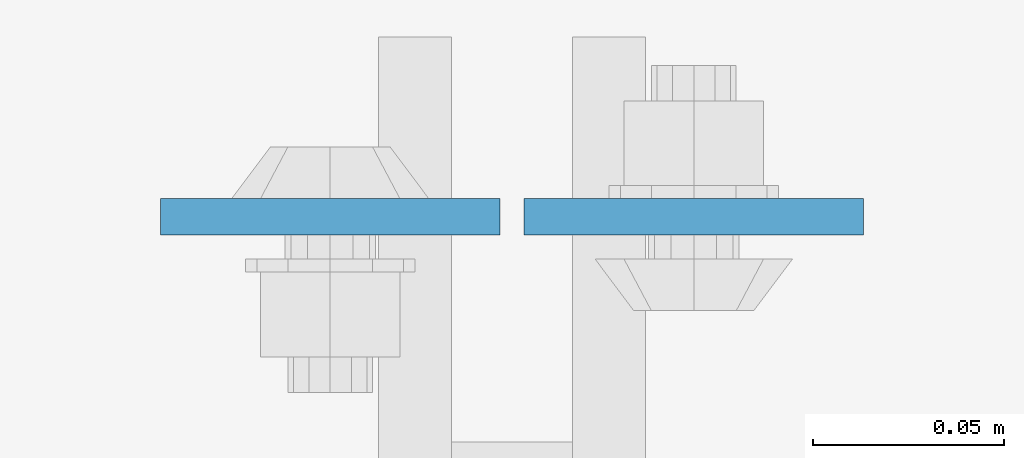
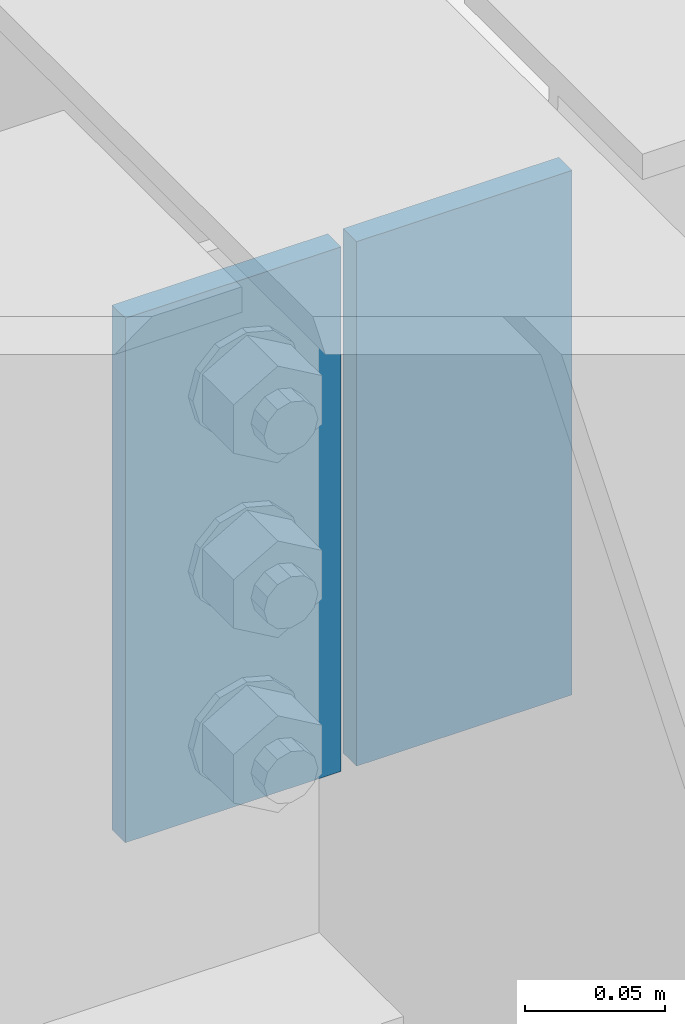
# One storey, part 3124 of 3843: 2 plates, 1 element without a shape of its own.
"""IFC2X3 building model written with IfcOpenShell, lengths in millimetres."""

import ifcopenshell
import ifcopenshell.guid

model = None  # the IFC model being written
_history = None  # IfcOwnerHistory: only IFC2X3 demands one
_inside = {}  # id of a spatial element -> (the spatial element, [elements in it])
_under = {}  # id of a project, library or spatial element -> (it, [spatial elements below it])
_declared = {}  # id of a project -> (the project, [libraries it declares])
_typed = {}  # id of a type object -> (the type object, [elements of that type])
_made_of = {}  # id of a material, layer set ... -> (it, [elements and type objects made of it])


def new_model(schema):
    """Start an empty IFC model of exactly this schema.

    Asked for "IFC4X3", IfcOpenShell would pick the latest addendum, in which some entities
    have other attributes; the version numbers below select the first issue.
    IFC2X3 requires an IfcOwnerHistory on every rooted entity: one is made here for all.
    """
    global model, _history
    if schema == "IFC4X3":
        model = ifcopenshell.file(schema_version=(4, 3, 0, 0))
    else:
        model = ifcopenshell.file(schema=schema)
    _inside.clear()
    _under.clear()
    _declared.clear()
    _typed.clear()
    _made_of.clear()
    _history = None
    if model.schema == "IFC2X3":
        org = make("IfcOrganization", Name="unknown")
        user = make(
            "IfcPersonAndOrganization",
            ThePerson=make("IfcPerson", FamilyName="unknown"),
            TheOrganization=org,
        )
        app = make(
            "IfcApplication",
            ApplicationDeveloper=org,
            Version="unknown",
            ApplicationFullName="unknown",
            ApplicationIdentifier="unknown",
        )
        _history = make(
            "IfcOwnerHistory",
            OwningUser=user,
            OwningApplication=app,
            ChangeAction="ADDED",
            CreationDate=0,
        )
    return model


def make(cls, **values):
    """One entity of the class cls with the attributes given. An attribute that is None is left unset."""
    return model.create_entity(
        cls, **{name: value for name, value in values.items() if value is not None}
    )


def rooted(cls, **values):
    """An entity with a GlobalId (a new one), such as an element, a storey or a relation."""
    return make(cls, GlobalId=ifcopenshell.guid.new(), OwnerHistory=_history, **values)


def si_unit(unit_type, name, prefix=None):
    """IfcSIUnit, for example si_unit("LENGTHUNIT", "METRE", prefix="MILLI")."""
    return make("IfcSIUnit", UnitType=unit_type, Prefix=prefix, Name=name)


def assignment(units):
    """IfcUnitAssignment: the units of a project."""
    return None if units is None else make("IfcUnitAssignment", Units=units)


def point(xyz):
    """IfcCartesianPoint."""
    return None if xyz is None else make("IfcCartesianPoint", Coordinates=xyz)


def direction(xyz):
    """IfcDirection."""
    return None if xyz is None else make("IfcDirection", DirectionRatios=xyz)


def frame(location, z_axis=None, x_axis=None):
    """IfcAxis2Placement3D, a coordinate frame: its origin and axes. An axis left out is left unset."""
    return make(
        "IfcAxis2Placement3D",
        Location=point(location),
        Axis=direction(z_axis),
        RefDirection=direction(x_axis),
    )


def origin_with_axes():
    """The frame at (0, 0, 0) with the z axis (0, 0, 1) and the x axis (1, 0, 0) written out."""
    return frame((0.0, 0.0, 0.0), z_axis=(0.0, 0.0, 1.0), x_axis=(1.0, 0.0, 0.0))


def place(relative_to, where):
    """IfcLocalPlacement: puts the frame where relative to a parent placement (None: the world)."""
    return make(
        "IfcLocalPlacement", PlacementRelTo=relative_to, RelativePlacement=where
    )


def context(
    kind, dimensions, precision=None, world=None, true_north=None, identifier=None
):
    """IfcGeometricRepresentationContext, for example the 3D "Model" context."""
    return make(
        "IfcGeometricRepresentationContext",
        ContextIdentifier=identifier,
        ContextType=kind,
        CoordinateSpaceDimension=dimensions,
        Precision=precision,
        WorldCoordinateSystem=world,
        TrueNorth=true_north,
    )


def subcontext(parent, identifier, kind, view, scale=None):
    """IfcGeometricRepresentationSubContext, for example "Body" below "Model"."""
    return make(
        "IfcGeometricRepresentationSubContext",
        ContextIdentifier=identifier,
        ContextType=kind,
        ParentContext=parent,
        TargetScale=scale,
        TargetView=view,
    )


def project(units=None, contexts=None):
    """IfcProject with its units and contexts."""
    return rooted(
        "IfcProject",
        Name="project",
        RepresentationContexts=contexts,
        UnitsInContext=assignment(units),
    )


def spatial(cls, under=None, at=None, **own):
    """A site, building, storey or space (cls), placed at a placement, below another one or the project."""
    s = rooted(cls, ObjectPlacement=at, **own)
    if under is not None:
        _under.setdefault(under.id(), (under, []))[1].append(s)
    return s


def faces_of(points, faces, orient=None, outer=None):
    """IfcFace entities. A face is a list of loops; a loop is a list of indices into points, from 0.

    orient and outer hold one flag for each loop. By default every Orientation is true, the
    first loop of a face is its IfcFaceOuterBound and the others are IfcFaceBound.
    """
    made = []
    for i, loops in enumerate(faces):
        bounds = []
        for j, loop in enumerate(loops):
            is_outer = j == 0 if outer is None else outer[i][j]
            bounds.append(
                make(
                    "IfcFaceOuterBound" if is_outer else "IfcFaceBound",
                    Bound=make("IfcPolyLoop", Polygon=[points[k] for k in loop]),
                    Orientation=True if orient is None else orient[i][j],
                )
            )
        made.append(make("IfcFace", Bounds=bounds))
    return made


def faceted_brep(points, faces, orient=None, outer=None, voids=None):
    """IfcFacetedBrep: a solid bounded by flat faces; with voids (closed shells), ...WithVoids."""
    shared = [point(p) for p in points]
    hull = make("IfcClosedShell", CfsFaces=faces_of(shared, faces, orient, outer))
    if voids is None:
        return make("IfcFacetedBrep", Outer=hull)
    return make(
        "IfcFacetedBrepWithVoids",
        Outer=hull,
        Voids=[
            make(cls, CfsFaces=faces_of(shared, fs, o, b)) for cls, fs, o, b in voids
        ],
    )


def shape(context_of_items, identifier, shape_type, items):
    """IfcShapeRepresentation: the items that make up one representation, for example the "Body"."""
    return make(
        "IfcShapeRepresentation",
        ContextOfItems=context_of_items,
        RepresentationIdentifier=identifier,
        RepresentationType=shape_type,
        Items=items,
    )


def material(Name=None, Category=None):
    """IfcMaterial."""
    return make("IfcMaterial", Name=Name, Category=Category)


def made_of(thing, what):
    """Note that an element or type object is made of a material, layer set ...; save() writes the relation."""
    if what is not None:
        _made_of.setdefault(what.id(), (what, []))[1].append(thing)
    return thing


def type_object(cls, material=None, **own):
    """A type object (cls), such as IfcWallType, which elements share."""
    return made_of(rooted(cls, **own), material)


def element(
    cls,
    number,
    at=None,
    inside=None,
    cuts=None,
    type_object=None,
    material=None,
    context=None,
    identifier="Body",
    shape_type=None,
    held_by="IfcProductDefinitionShape",
    body=None,
    shapes=None,
    **own,
):
    """One element of the class cls, such as IfcWall. Its Tag is "e" and its number.

    at: its placement. inside: the storey or other place that contains it. cuts: it is an
    opening in that element (IfcRelVoidsElement). A single representation is given by context,
    identifier, shape_type and body (its items); several are given by shapes. held_by: the class
    of the entity that holds the representations. save() writes the other relations.
    """
    e = rooted(cls, Tag="e%d" % number, ObjectPlacement=at, **own)
    if body is not None:
        shapes = [shape(context, identifier, shape_type, body)]
    if shapes is not None:
        e.Representation = make(held_by, Representations=shapes)
    if inside is not None:
        _inside.setdefault(inside.id(), (inside, []))[1].append(e)
    if cuts is not None:
        rooted(
            "IfcRelVoidsElement", RelatingBuildingElement=cuts, RelatedOpeningElement=e
        )
    if type_object is not None:
        _typed.setdefault(type_object.id(), (type_object, []))[1].append(e)
    return made_of(e, material)


def aggregate(whole, parts):
    """IfcRelAggregates: a whole, such as a stair, and the parts it consists of."""
    return rooted("IfcRelAggregates", RelatingObject=whole, RelatedObjects=parts)


def save(model, path):
    """Write the relations noted so far, then the file.

    IfcRelAggregates (storeys below a building ...), IfcRelContainedInSpatialStructure (elements
    in a storey), IfcRelDefinesByType, IfcRelAssociatesMaterial and IfcRelDeclares: one each for
    every whole, place, type object, material and project.
    """
    for whole, parts in _under.values():
        aggregate(whole, parts)
    for where, things in _inside.values():
        rooted(
            "IfcRelContainedInSpatialStructure",
            RelatedElements=things,
            RelatingStructure=where,
        )
    for kind, things in _typed.values():
        rooted("IfcRelDefinesByType", RelatedObjects=things, RelatingType=kind)
    for what, things in _made_of.values():
        rooted("IfcRelAssociatesMaterial", RelatedObjects=things, RelatingMaterial=what)
    for by, libraries in _declared.values():
        rooted("IfcRelDeclares", RelatingContext=by, RelatedDefinitions=libraries)
    model.write(path)


model = new_model("IFC2X3")

# Units and contexts
model_context = context("Model", 3, precision=1e-05, world=origin_with_axes())
body_context = subcontext(model_context, "Body", "Model", "MODEL_VIEW")
ifc_project = project(units=[si_unit("LENGTHUNIT", "METRE", prefix="MILLI"), si_unit("AREAUNIT", "SQUARE_METRE"), si_unit("VOLUMEUNIT", "CUBIC_METRE"), si_unit("MASSUNIT", "GRAM", prefix="KILO"), si_unit("TIMEUNIT", "SECOND"), si_unit("PLANEANGLEUNIT", "RADIAN"), si_unit("SOLIDANGLEUNIT", "STERADIAN"), si_unit("THERMODYNAMICTEMPERATUREUNIT", "DEGREE_CELSIUS"), si_unit("LUMINOUSINTENSITYUNIT", "LUMEN")], contexts=[model_context])

# Site, building, storey
site_placement = place(None, origin_with_axes())
site = spatial("IfcSite", under=ifc_project, at=site_placement, CompositionType="ELEMENT")
building_placement = place(site_placement, origin_with_axes())
building = spatial("IfcBuilding", under=site, at=building_placement, Name="Undefined", CompositionType="ELEMENT")
storey_placement = place(building_placement, origin_with_axes())
storey = spatial("IfcBuildingStorey", under=building, at=storey_placement, Name="Undefined", CompositionType="ELEMENT", Elevation=0.0)

# Assembly, plates
assembly_placement = place(storey_placement, origin_with_axes())
assembly = element("IfcElementAssembly", 1, at=assembly_placement, inside=storey, Name="BEAM", AssemblyPlace="NOTDEFINED", PredefinedType="RIGID_FRAME")
ifc_material = material(Name="STEEL/A572-50")
plate_type = type_object("IfcPlateType", PredefinedType="NOTDEFINED")
plate_1_placement = place(assembly_placement, frame((55933.975, 21376.9575, 42418.0), z_axis=(1.0, 0.0, 0.0), x_axis=(0.0, 0.0, -1.0)))
plate_1 = element("IfcPlate", 2, at=plate_1_placement, type_object=plate_type, material=ifc_material, Name="PLATE", context=body_context, shape_type="Brep", body=[
    faceted_brep([(0.0, -4.76249999999709, 0.0), (0.0, -4.76249999999709, 88.9000015258789), (0.0, 4.76249999999709, 88.9000015258789), (0.0, 4.76249999999709, 0.0), (228.600006102781, -4.7625000004191, 88.9000015257589), (228.600006102781, 4.76249999954598, 88.9000015257443), (228.600006103079, -4.7625000004482, 7.27595761418343e-12), (228.600006103079, 4.76249999954598, -7.27595761418343e-12)], [[[0, 1, 2, 3]], [[1, 4, 5, 2]], [[4, 6, 7, 5]], [[6, 0, 3, 7]], [[5, 7, 3, 2]], [[6, 4, 1, 0]]]),
])
plate_2_placement = place(assembly_placement, frame((55927.625, 21376.9575, 42418.0), z_axis=(-1.0, 0.0, 0.0), x_axis=(0.0, 0.0, -1.0)))
plate_2 = element("IfcPlate", 3, at=plate_2_placement, type_object=plate_type, material=ifc_material, Name="PLATE", context=body_context, shape_type="Brep", body=[
    faceted_brep([(0.0, -4.76249999999709, 0.0), (0.0, -4.76249999999709, 88.9000015258789), (0.0, 4.76249999999709, 88.9000015258789), (0.0, 4.76249999999709, 0.0), (228.600006102781, -4.7625000004191, 88.9000015257589), (228.600006102781, 4.76249999954598, 88.9000015257443), (228.600006103079, -4.7625000004482, 7.27595761418343e-12), (228.600006103079, 4.76249999954598, -7.27595761418343e-12)], [[[0, 1, 2, 3]], [[1, 4, 5, 2]], [[4, 6, 7, 5]], [[6, 0, 3, 7]], [[5, 7, 3, 2]], [[6, 4, 1, 0]]]),
])
aggregate(assembly, [plate_1, plate_2])

save(model, "model.ifc")
